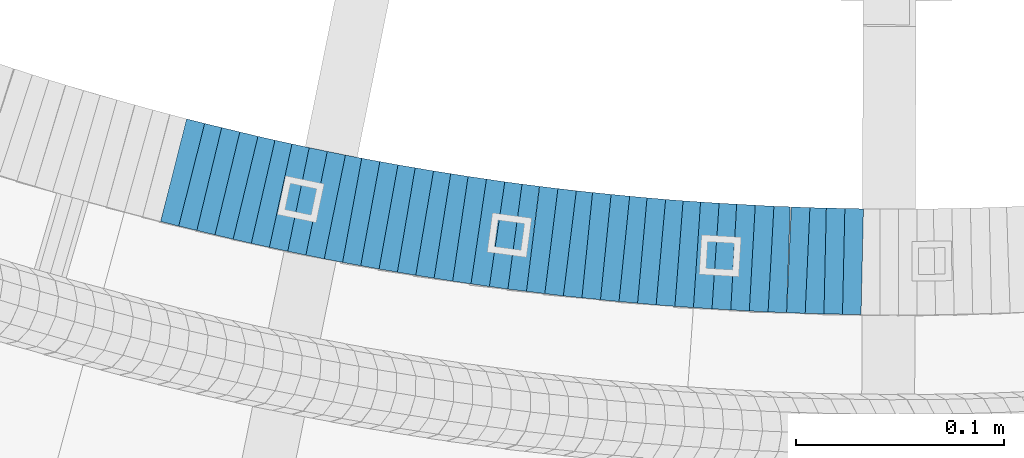
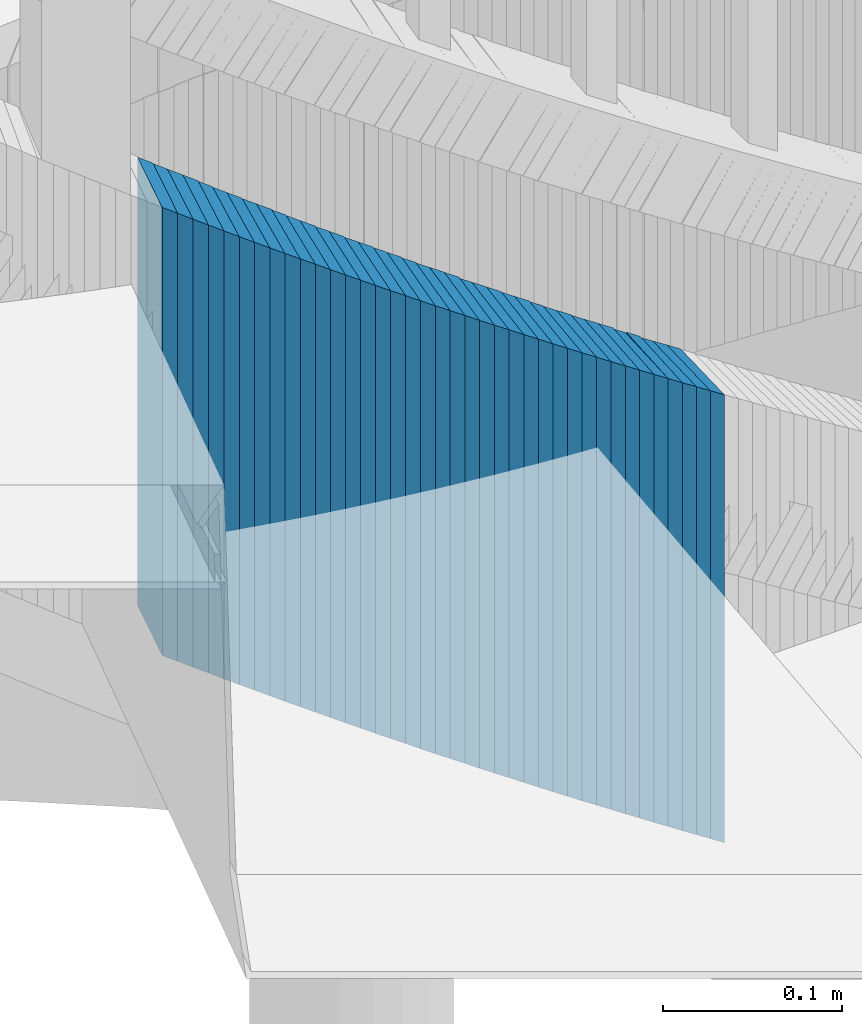
# One storey, part 880 of 975: 38 plates.
"""IFC2X3 building model written with IfcOpenShell, lengths in millimetres."""

from ifc_helpers import new_model, si_unit, frame, origin_with_axes, place, context, subcontext, project, spatial, faceted_brep, material, type_object, element, save


model = new_model("IFC2X3")

# Units and contexts
model_context = context("Model", 3, precision=1e-05, world=origin_with_axes())
body_context = subcontext(model_context, "Body", "Model", "MODEL_VIEW")
ifc_project = project(units=[si_unit("LENGTHUNIT", "METRE", prefix="MILLI"), si_unit("AREAUNIT", "SQUARE_METRE"), si_unit("VOLUMEUNIT", "CUBIC_METRE"), si_unit("MASSUNIT", "GRAM", prefix="KILO"), si_unit("TIMEUNIT", "SECOND"), si_unit("PLANEANGLEUNIT", "RADIAN"), si_unit("SOLIDANGLEUNIT", "STERADIAN"), si_unit("THERMODYNAMICTEMPERATUREUNIT", "DEGREE_CELSIUS"), si_unit("LUMINOUSINTENSITYUNIT", "LUMEN")], contexts=[model_context])

# Site, building, storey
site_placement = place(None, origin_with_axes())
site = spatial("IfcSite", under=ifc_project, at=site_placement, CompositionType="ELEMENT")
building_placement = place(site_placement, origin_with_axes())
building = spatial("IfcBuilding", under=site, at=building_placement, Name="Undefined", CompositionType="ELEMENT")
storey_placement = place(building_placement, origin_with_axes())
storey = spatial("IfcBuildingStorey", under=building, at=storey_placement, Name="Undefined", CompositionType="ELEMENT", Elevation=0.0)

# Plates
ifc_material = material(Name="STEEL/A36")
plate_type = type_object("IfcPlateType", PredefinedType="NOTDEFINED")
plate_1_placement = place(storey_placement, frame((34395.3922120382, 2048.29880946491, 3294.32500005032), z_axis=(-0.969483457737362, 0.245156735933585, 0.0), x_axis=(0.0, 0.0, 1.0)))
element("IfcPlate", 1, at=plate_1_placement, inside=storey, type_object=plate_type, material=ifc_material, Name="WALL", context=body_context, shape_type="Brep", body=[
    faceted_brep([(0.0, -25.3999999999724, -1.81898940354586e-11), (5.69999980926514, -25.4000000000124, 8.96939277650017), (5.69999980926514, 25.3999999999869, 8.96939277651836), (0.0, 25.3999999999869, 1.45519152283669e-11), (310.5, -25.4000000000124, 8.96939277650017), (310.5, 25.3999999999869, 8.96939277651836), (304.799987792969, -25.3999999999724, -1.81898940354586e-11), (304.799987792969, 25.3999999999869, 1.45519152283669e-11)], [[[0, 1, 2, 3]], [[1, 4, 5, 2]], [[4, 6, 7, 5]], [[6, 0, 3, 7]], [[5, 7, 3, 2]], [[6, 4, 1, 0]]]),
])
plate_2_placement = place(storey_placement, frame((34403.8251004839, 2046.26481773727, 3288.52500005032), z_axis=(-0.972082208620478, 0.234640532908391, 0.0), x_axis=(0.0, 0.0, 1.0)))
element("IfcPlate", 2, at=plate_2_placement, inside=storey, type_object=plate_type, material=ifc_material, Name="WALL", context=body_context, shape_type="Brep", body=[
    faceted_brep([(0.0, -25.3999999999724, -1.81898940354586e-11), (5.80000019073486, -25.3999999999942, 8.94930171964734), (5.80000019073486, 25.4000000000015, 8.94930171966917), (0.0, 25.3999999999869, 1.45519152283669e-11), (310.600006103516, -25.3999999999942, 8.94930171964734), (310.600006103516, 25.4000000000015, 8.94930171966917), (304.799987792969, -25.3999999999724, -1.81898940354586e-11), (304.799987792969, 25.3999999999869, 1.45519152283669e-11)], [[[0, 1, 2, 3]], [[1, 4, 5, 2]], [[4, 6, 7, 5]], [[6, 0, 3, 7]], [[5, 7, 3, 2]], [[6, 4, 1, 0]]]),
])
plate_3_placement = place(storey_placement, frame((34412.5251004863, 2044.16481773749, 3282.82500005032), z_axis=(-0.972082208620478, 0.234640532908391, 0.0), x_axis=(0.0, 0.0, 1.0)))
element("IfcPlate", 3, at=plate_3_placement, inside=storey, type_object=plate_type, material=ifc_material, Name="WALL", context=body_context, shape_type="Brep", body=[
    faceted_brep([(0.0, -25.3999999999724, -1.81898940354586e-11), (5.69999980926514, -25.3999999999869, 8.94930171964734), (5.69999980926514, 25.4000000000051, 8.94930171966917), (0.0, 25.3999999999869, 1.45519152283669e-11), (310.5, -25.3999999999869, 8.94930171964734), (310.5, 25.4000000000051, 8.94930171966917), (304.799987792969, -25.3999999999724, -1.81898940354586e-11), (304.799987792969, 25.3999999999869, 1.45519152283669e-11)], [[[0, 1, 2, 3]], [[1, 4, 5, 2]], [[4, 6, 7, 5]], [[6, 0, 3, 7]], [[5, 7, 3, 2]], [[6, 4, 1, 0]]]),
])
plate_4_placement = place(storey_placement, frame((34421.2251004888, 2042.06481773797, 3277.02500005032), z_axis=(-0.972082208620478, 0.234640532908391, 0.0), x_axis=(0.0, 0.0, 1.0)))
element("IfcPlate", 4, at=plate_4_placement, inside=storey, type_object=plate_type, material=ifc_material, Name="WALL", context=body_context, shape_type="Brep", body=[
    faceted_brep([(0.0, -25.3999999999724, -1.81898940354586e-11), (5.80000019073486, -25.3999999999942, 8.94930171964734), (5.80000019073486, 25.4000000000015, 8.94930171966917), (0.0, 25.3999999999869, 1.45519152283669e-11), (310.600006103516, -25.3999999999942, 8.94930171964734), (310.600006103516, 25.4000000000015, 8.94930171966917), (304.799987792969, -25.3999999999724, -1.81898940354586e-11), (304.799987792969, 25.3999999999869, 1.45519152283669e-11)], [[[0, 1, 2, 3]], [[1, 4, 5, 2]], [[4, 6, 7, 5]], [[6, 0, 3, 7]], [[5, 7, 3, 2]], [[6, 4, 1, 0]]]),
])
plate_5_placement = place(storey_placement, frame((34429.6558799515, 2040.12825277725, 3271.32500005032), z_axis=(-0.974579651097025, 0.224041299022304, 0.0), x_axis=(0.0, 0.0, 1.0)))
element("IfcPlate", 5, at=plate_5_placement, inside=storey, type_object=plate_type, material=ifc_material, Name="WALL", context=body_context, shape_type="Brep", body=[
    faceted_brep([(0.0, -25.3999999999724, -1.81898940354586e-11), (5.69999980926514, -25.3999999999542, 8.93084526058738), (5.69999980926514, 25.3999999999178, 8.93084526067832), (0.0, 25.3999999999869, 1.45519152283669e-11), (310.5, -25.3999999999542, 8.93084526058738), (310.5, 25.3999999999178, 8.93084526067832), (304.799987792969, -25.3999999999724, -1.81898940354586e-11), (304.799987792969, 25.3999999999869, 1.45519152283669e-11)], [[[0, 1, 2, 3]], [[1, 4, 5, 2]], [[4, 6, 7, 5]], [[6, 0, 3, 7]], [[5, 7, 3, 2]], [[6, 4, 1, 0]]]),
])
plate_6_placement = place(storey_placement, frame((34438.0846249187, 2038.28904940698, 3265.62500005032), z_axis=(-0.976973219192791, 0.213361967042104, 0.0), x_axis=(0.0, 0.0, 1.0)))
element("IfcPlate", 6, at=plate_6_placement, inside=storey, type_object=plate_type, material=ifc_material, Name="WALL", context=body_context, shape_type="Brep", body=[
    faceted_brep([(0.0, -25.3999999999724, -1.81898940354586e-11), (5.69999980926514, -25.4000000000269, 8.91066741947361), (5.69999980926514, 25.4000000000269, 8.91066741941904), (0.0, 25.3999999999869, 1.45519152283669e-11), (310.5, -25.4000000000269, 8.91066741947361), (310.5, 25.4000000000269, 8.91066741941904), (304.799987792969, -25.3999999999724, -1.81898940354586e-11), (304.799987792969, 25.3999999999869, 1.45519152283669e-11)], [[[0, 1, 2, 3]], [[1, 4, 5, 2]], [[4, 6, 7, 5]], [[6, 0, 3, 7]], [[5, 7, 3, 2]], [[6, 4, 1, 0]]]),
])
plate_7_placement = place(storey_placement, frame((34446.8257989563, 2036.40182344452, 3259.82500005032), z_axis=(-0.977476134047841, 0.211045984010329, 0.0), x_axis=(0.0, 0.0, 1.0)))
element("IfcPlate", 7, at=plate_7_placement, inside=storey, type_object=plate_type, material=ifc_material, Name="WALL", context=body_context, shape_type="Brep", body=[
    faceted_brep([(0.0, -25.3999999999724, -1.81898940354586e-11), (5.80000019073486, -25.3999999999978, 9.00055599211555), (5.80000019073486, 25.3999999999651, 9.00055599218103), (0.0, 25.3999999999869, 1.45519152283669e-11), (310.600006103516, -25.3999999999978, 9.00055599211555), (310.600006103516, 25.3999999999651, 9.00055599218103), (304.799987792969, -25.3999999999724, -1.81898940354586e-11), (304.799987792969, 25.3999999999869, 1.45519152283669e-11)], [[[0, 1, 2, 3]], [[1, 4, 5, 2]], [[4, 6, 7, 5]], [[6, 0, 3, 7]], [[5, 7, 3, 2]], [[6, 4, 1, 0]]]),
])
plate_8_placement = place(storey_placement, frame((34455.3114133024, 2034.64714429571, 3254.12500005032), z_axis=(-0.979260419534469, 0.202605603903684, 0.0), x_axis=(0.0, 0.0, 1.0)))
element("IfcPlate", 8, at=plate_8_placement, inside=storey, type_object=plate_type, material=ifc_material, Name="WALL", context=body_context, shape_type="Brep", body=[
    faceted_brep([(0.0, -25.3999999999724, -1.81898940354586e-11), (5.69999980926514, -25.4000000000306, 8.88144111634756), (5.69999980926514, 25.4000000000378, 8.88144111629663), (0.0, 25.3999999999869, 1.45519152283669e-11), (310.5, -25.4000000000306, 8.88144111634756), (310.5, 25.4000000000378, 8.88144111629663), (304.799987792969, -25.3999999999724, -1.81898940354586e-11), (304.799987792969, 25.3999999999869, 1.45519152283669e-11)], [[[0, 1, 2, 3]], [[1, 4, 5, 2]], [[4, 6, 7, 5]], [[6, 0, 3, 7]], [[5, 7, 3, 2]], [[6, 4, 1, 0]]]),
])
plate_9_placement = place(storey_placement, frame((34464.0552953596, 2032.8586889202, 3248.42500005032), z_axis=(-0.979714932300414, 0.200396236061448, 0.0), x_axis=(0.0, 0.0, 1.0)))
element("IfcPlate", 9, at=plate_9_placement, inside=storey, type_object=plate_type, material=ifc_material, Name="WALL", context=body_context, shape_type="Brep", body=[
    faceted_brep([(0.0, -25.3999999999724, -1.81898940354586e-11), (5.69999980926514, -25.3999999999542, 8.98276138300935), (5.69999980926514, 25.3999999999614, 8.98276138309302), (0.0, 25.3999999999869, 1.45519152283669e-11), (310.5, -25.3999999999542, 8.98276138300935), (310.5, 25.3999999999614, 8.98276138309302), (304.799987792969, -25.3999999999724, -1.81898940354586e-11), (304.799987792969, 25.3999999999869, 1.45519152283669e-11)], [[[0, 1, 2, 3]], [[1, 4, 5, 2]], [[4, 6, 7, 5]], [[6, 0, 3, 7]], [[5, 7, 3, 2]], [[6, 4, 1, 0]]]),
])
plate_10_placement = place(storey_placement, frame((34472.5829753509, 2031.21284178494, 3242.72500005032), z_axis=(-0.98184693485788, 0.189674975972544, 0.0), x_axis=(0.0, 0.0, 1.0)))
element("IfcPlate", 10, at=plate_10_placement, inside=storey, type_object=plate_type, material=ifc_material, Name="WALL", context=body_context, shape_type="Brep", body=[
    faceted_brep([(0.0, -25.3999999999724, -1.81898940354586e-11), (5.69999980926514, -25.3999999999105, 8.96270084374919), (5.69999980926514, 25.399999999936, 8.96270084385469), (0.0, 25.3999999999869, 1.45519152283669e-11), (310.5, -25.3999999999105, 8.96270084374919), (310.5, 25.399999999936, 8.96270084385469), (304.799987792969, -25.3999999999724, -1.81898940354586e-11), (304.799987792969, 25.3999999999869, 1.45519152283669e-11)], [[[0, 1, 2, 3]], [[1, 4, 5, 2]], [[4, 6, 7, 5]], [[6, 0, 3, 7]], [[5, 7, 3, 2]], [[6, 4, 1, 0]]]),
])
plate_11_placement = place(storey_placement, frame((34481.0594481925, 2029.65498582379, 3236.92500005032), z_axis=(-0.983506148975214, 0.180874693995442, 0.0), x_axis=(0.0, 0.0, 1.0)))
element("IfcPlate", 11, at=plate_11_placement, inside=storey, type_object=plate_type, material=ifc_material, Name="WALL", context=body_context, shape_type="Brep", body=[
    faceted_brep([(0.0, -25.3999999999724, -1.81898940354586e-11), (5.80000019073486, -25.4000000000378, 8.84590339667557), (5.80000019073486, 25.4000000000415, 8.8459033965446), (0.0, 25.3999999999869, 1.45519152283669e-11), (310.600006103516, -25.4000000000378, 8.84590339667557), (310.600006103516, 25.4000000000415, 8.8459033965446), (304.799987792969, -25.3999999999724, -1.81898940354586e-11), (304.799987792969, 25.3999999999869, 1.45519152283669e-11)], [[[0, 1, 2, 3]], [[1, 4, 5, 2]], [[4, 6, 7, 5]], [[6, 0, 3, 7]], [[5, 7, 3, 2]], [[6, 4, 1, 0]]]),
])
plate_12_placement = place(storey_placement, frame((34489.8089210954, 2028.064225357, 3231.22500005032), z_axis=(-0.983869910131907, 0.178885438023983, 0.0), x_axis=(0.0, 0.0, 1.0)))
element("IfcPlate", 12, at=plate_12_placement, inside=storey, type_object=plate_type, material=ifc_material, Name="WALL", context=body_context, shape_type="Brep", body=[
    faceted_brep([(0.0, -25.3999999999724, -1.81898940354586e-11), (5.69999980926514, -25.4000000000851, 8.94035816198448), (5.69999980926514, 25.4000000000524, 8.94035816188989), (0.0, 25.3999999999869, 1.45519152283669e-11), (310.5, -25.4000000000851, 8.94035816198448), (310.5, 25.4000000000524, 8.94035816188989), (304.799987792969, -25.3999999999724, -1.81898940354586e-11), (304.799987792969, 25.3999999999869, 1.45519152283669e-11)], [[[0, 1, 2, 3]], [[1, 4, 5, 2]], [[4, 6, 7, 5]], [[6, 0, 3, 7]], [[5, 7, 3, 2]], [[6, 4, 1, 0]]]),
])
plate_13_placement = place(storey_placement, frame((34498.3332177071, 2026.61278522843, 3225.52500005032), z_axis=(-0.985781716087097, 0.168030974014846, 0.0), x_axis=(0.0, 0.0, 1.0)))
element("IfcPlate", 13, at=plate_13_placement, inside=storey, type_object=plate_type, material=ifc_material, Name="WALL", context=body_context, shape_type="Brep", body=[
    faceted_brep([(0.0, -25.3999999999724, -1.81898940354586e-11), (5.69999980926514, -25.3999999999542, 8.93084526058738), (5.69999980926514, 25.3999999999178, 8.93084526067832), (0.0, 25.3999999999869, 1.45519152283669e-11), (310.5, -25.3999999999542, 8.93084526058738), (310.5, 25.3999999999178, 8.93084526067832), (304.799987792969, -25.3999999999724, -1.81898940354586e-11), (304.799987792969, 25.3999999999869, 1.45519152283669e-11)], [[[0, 1, 2, 3]], [[1, 4, 5, 2]], [[4, 6, 7, 5]], [[6, 0, 3, 7]], [[5, 7, 3, 2]], [[6, 4, 1, 0]]]),
])
plate_14_placement = place(storey_placement, frame((34507.1332177047, 2025.11278522859, 3219.72500005032), z_axis=(-0.985781716087097, 0.168030974014846, 0.0), x_axis=(0.0, 0.0, 1.0)))
element("IfcPlate", 14, at=plate_14_placement, inside=storey, type_object=plate_type, material=ifc_material, Name="WALL", context=body_context, shape_type="Brep", body=[
    faceted_brep([(0.0, -25.3999999999724, -1.81898940354586e-11), (5.80000019073486, -25.3999999999869, 8.93084526053281), (5.80000019073486, 25.3999999999833, 8.9308452607147), (0.0, 25.3999999999869, 1.45519152283669e-11), (310.600006103516, -25.3999999999869, 8.93084526053281), (310.600006103516, 25.3999999999833, 8.9308452607147), (304.799987792969, -25.3999999999724, -1.81898940354586e-11), (304.799987792969, 25.3999999999869, 1.45519152283669e-11)], [[[0, 1, 2, 3]], [[1, 4, 5, 2]], [[4, 6, 7, 5]], [[6, 0, 3, 7]], [[5, 7, 3, 2]], [[6, 4, 1, 0]]]),
])
plate_15_placement = place(storey_placement, frame((34515.6559532135, 2023.75846941976, 3214.02500005032), z_axis=(-0.987580306285744, 0.157115049045459, 0.0), x_axis=(0.0, 0.0, 1.0)))
element("IfcPlate", 15, at=plate_15_placement, inside=storey, type_object=plate_type, material=ifc_material, Name="WALL", context=body_context, shape_type="Brep", body=[
    faceted_brep([(0.0, -25.3999999999724, -1.81898940354586e-11), (5.69999980926514, -25.4000000000269, 8.91066741947361), (5.69999980926514, 25.4000000000269, 8.91066741941904), (0.0, 25.3999999999869, 1.45519152283669e-11), (310.5, -25.4000000000269, 8.91066741947361), (310.5, 25.4000000000269, 8.91066741941904), (304.799987792969, -25.3999999999724, -1.81898940354586e-11), (304.799987792969, 25.3999999999869, 1.45519152283669e-11)], [[[0, 1, 2, 3]], [[1, 4, 5, 2]], [[4, 6, 7, 5]], [[6, 0, 3, 7]], [[5, 7, 3, 2]], [[6, 4, 1, 0]]]),
])
plate_16_placement = place(storey_placement, frame((34524.5122023689, 2022.36539067251, 3208.32500005032), z_axis=(-0.987852796552575, 0.155392574929619, 0.0), x_axis=(0.0, 0.0, 1.0)))
element("IfcPlate", 16, at=plate_16_placement, inside=storey, type_object=plate_type, material=ifc_material, Name="WALL", context=body_context, shape_type="Brep", body=[
    faceted_brep([(0.0, -25.3999999999724, -1.81898940354586e-11), (5.69999980926514, -25.4000000000233, 9.01387786867781), (5.69999980926514, 25.400000000016, 9.01387786863415), (0.0, 25.3999999999869, 1.45519152283669e-11), (310.5, -25.4000000000233, 9.01387786867781), (310.5, 25.400000000016, 9.01387786863415), (304.799987792969, -25.3999999999724, -1.81898940354586e-11), (304.799987792969, 25.3999999999869, 1.45519152283669e-11)], [[[0, 1, 2, 3]], [[1, 4, 5, 2]], [[4, 6, 7, 5]], [[6, 0, 3, 7]], [[5, 7, 3, 2]], [[6, 4, 1, 0]]]),
])
plate_17_placement = place(storey_placement, frame((34533.077218307, 2021.10122853883, 3202.52500005032), z_axis=(-0.989263736178206, 0.146141234026326, 0.0), x_axis=(0.0, 0.0, 1.0)))
element("IfcPlate", 17, at=plate_17_placement, inside=storey, type_object=plate_type, material=ifc_material, Name="WALL", context=body_context, shape_type="Brep", body=[
    faceted_brep([(0.0, -25.3999999999724, -1.81898940354586e-11), (5.80000019073486, -25.3999999999687, 8.90449333185097), (5.80000019073486, 25.3999999999833, 8.90449333192373), (0.0, 25.3999999999869, 1.45519152283669e-11), (310.600006103516, -25.3999999999687, 8.90449333185097), (310.600006103516, 25.3999999999833, 8.90449333192373), (304.799987792969, -25.3999999999724, -1.81898940354586e-11), (304.799987792969, 25.3999999999869, 1.45519152283669e-11)], [[[0, 1, 2, 3]], [[1, 4, 5, 2]], [[4, 6, 7, 5]], [[6, 0, 3, 7]], [[5, 7, 3, 2]], [[6, 4, 1, 0]]]),
])
plate_18_placement = place(storey_placement, frame((34541.877218304, 2019.80122853885, 3196.82500005032), z_axis=(-0.989263736178206, 0.146141234026326, 0.0), x_axis=(0.0, 0.0, 1.0)))
element("IfcPlate", 18, at=plate_18_placement, inside=storey, type_object=plate_type, material=ifc_material, Name="WALL", context=body_context, shape_type="Brep", body=[
    faceted_brep([(0.0, -25.3999999999724, -1.81898940354586e-11), (5.69999980926514, -25.3999999999469, 8.90224647518698), (5.69999980926514, 25.399999999936, 8.90224647526338), (0.0, 25.3999999999869, 1.45519152283669e-11), (310.5, -25.3999999999469, 8.90224647518698), (310.5, 25.399999999936, 8.90224647526338), (304.799987792969, -25.3999999999724, -1.81898940354586e-11), (304.799987792969, 25.3999999999869, 1.45519152283669e-11)], [[[0, 1, 2, 3]], [[1, 4, 5, 2]], [[4, 6, 7, 5]], [[6, 0, 3, 7]], [[5, 7, 3, 2]], [[6, 4, 1, 0]]]),
])
plate_19_placement = place(storey_placement, frame((34550.4592382899, 2018.64615072209, 3191.12500005033), z_axis=(-0.991032326071817, 0.133622336009683, 0.0), x_axis=(0.0, 0.0, 1.0)))
element("IfcPlate", 19, at=plate_19_placement, inside=storey, type_object=plate_type, material=ifc_material, Name="WALL", context=body_context, shape_type="Brep", body=[
    faceted_brep([(0.0, -25.3999999999724, -1.81898940354586e-11), (5.69999980926514, -25.3999999999542, 8.98276138300935), (5.69999980926514, 25.3999999999614, 8.98276138309302), (0.0, 25.3999999999869, 1.45519152283669e-11), (310.5, -25.3999999999542, 8.98276138300935), (310.5, 25.3999999999614, 8.98276138309302), (304.799987792969, -25.3999999999724, -1.81898940354586e-11), (304.799987792969, 25.3999999999869, 1.45519152283669e-11)], [[[0, 1, 2, 3]], [[1, 4, 5, 2]], [[4, 6, 7, 5]], [[6, 0, 3, 7]], [[5, 7, 3, 2]], [[6, 4, 1, 0]]]),
])
plate_20_placement = place(storey_placement, frame((34559.0808501246, 2017.5821211099, 3185.42500005033), z_axis=(-0.99244848307505, 0.122662172009276, 0.0), x_axis=(0.0, 0.0, 1.0)))
element("IfcPlate", 20, at=plate_20_placement, inside=storey, type_object=plate_type, material=ifc_material, Name="WALL", context=body_context, shape_type="Brep", body=[
    faceted_brep([(0.0, -25.3999999999724, -1.81898940354586e-11), (5.69999980926514, -25.4000000000124, 8.96939277650017), (5.69999980926514, 25.3999999999869, 8.96939277651836), (0.0, 25.3999999999869, 1.45519152283669e-11), (310.5, -25.4000000000124, 8.96939277650017), (310.5, 25.3999999999869, 8.96939277651836), (304.799987792969, -25.3999999999724, -1.81898940354586e-11), (304.799987792969, 25.3999999999869, 1.45519152283669e-11)], [[[0, 1, 2, 3]], [[1, 4, 5, 2]], [[4, 6, 7, 5]], [[6, 0, 3, 7]], [[5, 7, 3, 2]], [[6, 4, 1, 0]]]),
])
plate_21_placement = place(storey_placement, frame((34567.9157132253, 2016.47778770714, 3179.62500005033), z_axis=(-0.992277876667514, 0.12403473495844, 0.0), x_axis=(0.0, 0.0, 1.0)))
element("IfcPlate", 21, at=plate_21_placement, inside=storey, type_object=plate_type, material=ifc_material, Name="WALL", context=body_context, shape_type="Brep", body=[
    faceted_brep([(0.0, -25.3999999999724, -1.81898940354586e-11), (5.80000019073486, -25.4000000000042, 8.87299251562217), (5.80000019073486, 25.3999999999987, 8.87299251556396), (0.0, 25.3999999999869, 1.45519152283669e-11), (310.600006103516, -25.4000000000042, 8.87299251562217), (310.600006103516, 25.3999999999987, 8.87299251556396), (304.799987792969, -25.3999999999724, -1.81898940354586e-11), (304.799987792969, 25.3999999999869, 1.45519152283669e-11)], [[[0, 1, 2, 3]], [[1, 4, 5, 2]], [[4, 6, 7, 5]], [[6, 0, 3, 7]], [[5, 7, 3, 2]], [[6, 4, 1, 0]]]),
])
plate_22_placement = place(storey_placement, frame((34576.7808501268, 2015.38212111014, 3173.92500005033), z_axis=(-0.99244848307505, 0.122662172009276, 0.0), x_axis=(0.0, 0.0, 1.0)))
element("IfcPlate", 22, at=plate_22_placement, inside=storey, type_object=plate_type, material=ifc_material, Name="WALL", context=body_context, shape_type="Brep", body=[
    faceted_brep([(0.0, -25.3999999999724, -1.81898940354586e-11), (5.69999980926514, -25.4000000000124, 8.96939277650017), (5.69999980926514, 25.3999999999869, 8.96939277651836), (0.0, 25.3999999999869, 1.45519152283669e-11), (310.5, -25.4000000000124, 8.96939277650017), (310.5, 25.3999999999869, 8.96939277651836), (304.799987792969, -25.3999999999724, -1.81898940354586e-11), (304.799987792969, 25.3999999999869, 1.45519152283669e-11)], [[[0, 1, 2, 3]], [[1, 4, 5, 2]], [[4, 6, 7, 5]], [[6, 0, 3, 7]], [[5, 7, 3, 2]], [[6, 4, 1, 0]]]),
])
plate_23_placement = place(storey_placement, frame((34585.1207372207, 2014.5450472985, 3168.22500005033), z_axis=(-0.994925892068904, 0.100610483006968, 0.0), x_axis=(0.0, 0.0, 1.0)))
element("IfcPlate", 23, at=plate_23_placement, inside=storey, type_object=plate_type, material=ifc_material, Name="WALL", context=body_context, shape_type="Brep", body=[
    faceted_brep([(0.0, -25.3999999999724, -1.81898940354586e-11), (5.69999980926514, -25.3999999999869, 8.94930171964734), (5.69999980926514, 25.4000000000051, 8.94930171966917), (0.0, 25.3999999999869, 1.45519152283669e-11), (310.5, -25.3999999999869, 8.94930171964734), (310.5, 25.4000000000051, 8.94930171966917), (304.799987792969, -25.3999999999724, -1.81898940354586e-11), (304.799987792969, 25.3999999999869, 1.45519152283669e-11)], [[[0, 1, 2, 3]], [[1, 4, 5, 2]], [[4, 6, 7, 5]], [[6, 0, 3, 7]], [[5, 7, 3, 2]], [[6, 4, 1, 0]]]),
])
plate_24_placement = place(storey_placement, frame((34594.0207372153, 2013.64504729841, 3162.42500005033), z_axis=(-0.994925892068904, 0.100610483006968, 0.0), x_axis=(0.0, 0.0, 1.0)))
element("IfcPlate", 24, at=plate_24_placement, inside=storey, type_object=plate_type, material=ifc_material, Name="WALL", context=body_context, shape_type="Brep", body=[
    faceted_brep([(0.0, -25.3999999999724, -1.81898940354586e-11), (5.80000019073486, -25.3999999999942, 8.94930171964734), (5.80000019073486, 25.4000000000015, 8.94930171966917), (0.0, 25.3999999999869, 1.45519152283669e-11), (310.600006103516, -25.3999999999942, 8.94930171964734), (310.600006103516, 25.4000000000015, 8.94930171966917), (304.799987792969, -25.3999999999724, -1.81898940354586e-11), (304.799987792969, 25.3999999999869, 1.45519152283669e-11)], [[[0, 1, 2, 3]], [[1, 4, 5, 2]], [[4, 6, 7, 5]], [[6, 0, 3, 7]], [[5, 7, 3, 2]], [[6, 4, 1, 0]]]),
])
plate_25_placement = place(storey_placement, frame((34602.9207372098, 2012.74504729836, 3156.72500005033), z_axis=(-0.994925892068904, 0.100610483006968, 0.0), x_axis=(0.0, 0.0, 1.0)))
element("IfcPlate", 25, at=plate_25_placement, inside=storey, type_object=plate_type, material=ifc_material, Name="WALL", context=body_context, shape_type="Brep", body=[
    faceted_brep([(0.0, -25.3999999999724, -1.81898940354586e-11), (5.69999980926514, -25.3999999999869, 8.94930171964734), (5.69999980926514, 25.4000000000051, 8.94930171966917), (0.0, 25.3999999999869, 1.45519152283669e-11), (310.5, -25.3999999999869, 8.94930171964734), (310.5, 25.4000000000051, 8.94930171966917), (304.799987792969, -25.3999999999724, -1.81898940354586e-11), (304.799987792969, 25.3999999999869, 1.45519152283669e-11)], [[[0, 1, 2, 3]], [[1, 4, 5, 2]], [[4, 6, 7, 5]], [[6, 0, 3, 7]], [[5, 7, 3, 2]], [[6, 4, 1, 0]]]),
])
plate_26_placement = place(storey_placement, frame((34611.5392088716, 2011.97193399573, 3150.92500005033), z_axis=(-0.995984423457655, 0.0895266900411377, 0.0), x_axis=(0.0, 0.0, 1.0)))
element("IfcPlate", 26, at=plate_26_placement, inside=storey, type_object=plate_type, material=ifc_material, Name="WALL", context=body_context, shape_type="Brep", body=[
    faceted_brep([(0.0, -25.3999999999724, -1.81898940354586e-11), (5.80000019073486, -25.4000000000087, 8.9375610351708), (5.80000019073486, 25.400000000016, 8.93756103512715), (0.0, 25.3999999999869, 1.45519152283669e-11), (310.600006103516, -25.4000000000087, 8.9375610351708), (310.600006103516, 25.400000000016, 8.93756103512715), (304.799987792969, -25.3999999999724, -1.81898940354586e-11), (304.799987792969, 25.3999999999869, 1.45519152283669e-11)], [[[0, 1, 2, 3]], [[1, 4, 5, 2]], [[4, 6, 7, 5]], [[6, 0, 3, 7]], [[5, 7, 3, 2]], [[6, 4, 1, 0]]]),
])
plate_27_placement = place(storey_placement, frame((34620.4392088747, 2011.17193399579, 3145.22500005033), z_axis=(-0.995984423457655, 0.0895266900411377, 0.0), x_axis=(0.0, 0.0, 1.0)))
element("IfcPlate", 27, at=plate_27_placement, inside=storey, type_object=plate_type, material=ifc_material, Name="WALL", context=body_context, shape_type="Brep", body=[
    faceted_brep([(0.0, -25.3999999999724, -1.81898940354586e-11), (5.69999980926514, -25.4000000000851, 8.94035816198448), (5.69999980926514, 25.4000000000524, 8.94035816188989), (0.0, 25.3999999999869, 1.45519152283669e-11), (310.5, -25.4000000000851, 8.94035816198448), (310.5, 25.4000000000524, 8.94035816188989), (304.799987792969, -25.3999999999724, -1.81898940354586e-11), (304.799987792969, 25.3999999999869, 1.45519152283669e-11)], [[[0, 1, 2, 3]], [[1, 4, 5, 2]], [[4, 6, 7, 5]], [[6, 0, 3, 7]], [[5, 7, 3, 2]], [[6, 4, 1, 0]]]),
])
plate_28_placement = place(storey_placement, frame((34629.134838025, 2010.49744929907, 3139.42500005033), z_axis=(-0.996988962963333, 0.0775435859971479, 0.0), x_axis=(0.0, 0.0, 1.0)))
element("IfcPlate", 28, at=plate_28_placement, inside=storey, type_object=plate_type, material=ifc_material, Name="WALL", context=body_context, shape_type="Brep", body=[
    faceted_brep([(0.0, -25.3999999999724, -1.81898940354586e-11), (5.80000019073486, -25.4000000000015, 9.02718162538804), (5.80000019073486, 25.4000000000005, 9.02718162535166), (0.0, 25.3999999999869, 1.45519152283669e-11), (310.600006103516, -25.4000000000015, 9.02718162538804), (310.600006103516, 25.4000000000005, 9.02718162535166), (304.799987792969, -25.3999999999724, -1.81898940354586e-11), (304.799987792969, 25.3999999999869, 1.45519152283669e-11)], [[[0, 1, 2, 3]], [[1, 4, 5, 2]], [[4, 6, 7, 5]], [[6, 0, 3, 7]], [[5, 7, 3, 2]], [[6, 4, 1, 0]]]),
])
for number, where, z_axis, x_axis, name in (
    (29, (34637.7737124614, 2009.91640566123, 3133.72500005033), (-0.99773527642945, 0.0672630520289514, 0.0), (0.0, 0.0, 1.0), "WALL"),
    (30, (34646.6737124605, 2009.31640566107, 3128.02500005033), (-0.99773527642945, 0.0672630520289514, 0.0), (0.0, 0.0, 1.0), "WALL"),
):
    element("IfcPlate", number, at=place(storey_placement, frame(where, z_axis=z_axis, x_axis=x_axis)), inside=storey, type_object=plate_type, material=ifc_material, Name=name, context=body_context, shape_type="Brep", body=[
        faceted_brep([(0.0, -25.3999999999724, -1.81898940354586e-11), (5.69999980926514, -25.4000000000269, 8.9196414947728), (5.69999980926514, 25.3999999999796, 8.91964149476189), (0.0, 25.3999999999869, 1.45519152283669e-11), (310.5, -25.4000000000269, 8.9196414947728), (310.5, 25.3999999999796, 8.91964149476189), (304.799987792969, -25.3999999999724, -1.81898940354586e-11), (304.799987792969, 25.3999999999869, 1.45519152283669e-11)], [[[0, 1, 2, 3]], [[1, 4, 5, 2]], [[4, 6, 7, 5]], [[6, 0, 3, 7]], [[5, 7, 3, 2]], [[6, 4, 1, 0]]]),
    ])
plate_29_placement = place(storey_placement, frame((34655.3741694461, 2008.83482261074, 3122.22500005033), z_axis=(-0.998460353183874, 0.0554700200102153, 0.0), x_axis=(0.0, 0.0, 1.0)))
element("IfcPlate", 31, at=plate_29_placement, inside=storey, type_object=plate_type, material=ifc_material, Name="WALL", context=body_context, shape_type="Brep", body=[
    faceted_brep([(0.0, -25.3999999999724, -1.81898940354586e-11), (5.80000019073486, -25.400000000016, 9.01387786866326), (5.80000019073486, 25.4000000000306, 9.01387786864143), (0.0, 25.3999999999869, 1.45519152283669e-11), (310.600006103515, -25.400000000016, 9.01387786866326), (310.600006103515, 25.4000000000306, 9.01387786864143), (304.799987792969, -25.3999999999724, -1.81898940354586e-11), (304.799987792969, 25.3999999999869, 1.45519152283669e-11)], [[[0, 1, 2, 3]], [[1, 4, 5, 2]], [[4, 6, 7, 5]], [[6, 0, 3, 7]], [[5, 7, 3, 2]], [[6, 4, 1, 0]]]),
])
plate_30_placement = place(storey_placement, frame((34664.2899506657, 2008.33394095085, 3116.52500005033), z_axis=(-0.99842564215979, 0.056091328008977, 0.0), x_axis=(0.0, 0.0, 1.0)))
element("IfcPlate", 32, at=plate_30_placement, inside=storey, type_object=plate_type, material=ifc_material, Name="WALL", context=body_context, shape_type="Brep", body=[
    faceted_brep([(0.0, -25.3999999999724, -1.81898940354586e-11), (5.69999980926514, -25.4000000000269, 8.91066741947361), (5.69999980926514, 25.4000000000269, 8.91066741941904), (0.0, 25.3999999999869, 1.45519152283669e-11), (310.5, -25.4000000000269, 8.91066741947361), (310.5, 25.4000000000269, 8.91066741941904), (304.799987792969, -25.3999999999724, -1.81898940354586e-11), (304.799987792969, 25.3999999999869, 1.45519152283669e-11)], [[[0, 1, 2, 3]], [[1, 4, 5, 2]], [[4, 6, 7, 5]], [[6, 0, 3, 7]], [[5, 7, 3, 2]], [[6, 4, 1, 0]]]),
])
plate_31_placement = place(storey_placement, frame((34673.2741694414, 2007.83482261095, 3110.72500005033), z_axis=(-0.998460353183874, 0.0554700200102153, 0.0), x_axis=(0.0, 0.0, 1.0)))
element("IfcPlate", 33, at=plate_31_placement, inside=storey, type_object=plate_type, material=ifc_material, Name="WALL", context=body_context, shape_type="Brep", body=[
    faceted_brep([(0.0, -25.3999999999724, -1.81898940354586e-11), (5.80000019073486, -25.400000000016, 9.01387786866326), (5.80000019073486, 25.4000000000306, 9.01387786864143), (0.0, 25.3999999999869, 1.45519152283669e-11), (310.600006103515, -25.400000000016, 9.01387786866326), (310.600006103515, 25.4000000000306, 9.01387786864143), (304.799987792969, -25.3999999999724, -1.81898940354586e-11), (304.799987792969, 25.3999999999869, 1.45519152283669e-11)], [[[0, 1, 2, 3]], [[1, 4, 5, 2]], [[4, 6, 7, 5]], [[6, 0, 3, 7]], [[5, 7, 3, 2]], [[6, 4, 1, 0]]]),
])
plate_32_placement = place(storey_placement, frame((34681.6209247209, 2007.55951192888, 3105.02500005033), z_axis=(-0.999432373568723, 0.0336887319854628, 0.0), x_axis=(0.0, 0.0, 1.0)))
element("IfcPlate", 34, at=plate_32_placement, inside=storey, type_object=plate_type, material=ifc_material, Name="WALL", context=body_context, shape_type="Brep", body=[
    faceted_brep([(0.0, -25.3999999999724, -1.81898940354586e-11), (5.69999980926514, -25.4000000000269, 8.91066741947361), (5.69999980926514, 25.4000000000269, 8.91066741941904), (0.0, 25.3999999999869, 1.45519152283669e-11), (310.5, -25.4000000000269, 8.91066741947361), (310.5, 25.4000000000269, 8.91066741941904), (304.799987792969, -25.3999999999724, -1.81898940354586e-11), (304.799987792969, 25.3999999999869, 1.45519152283669e-11)], [[[0, 1, 2, 3]], [[1, 4, 5, 2]], [[4, 6, 7, 5]], [[6, 0, 3, 7]], [[5, 7, 3, 2]], [[6, 4, 1, 0]]]),
])
plate_33_placement = place(storey_placement, frame((34690.8056527481, 2007.14831511167, 3099.22500005033), z_axis=(-0.998991554001901, 0.0448984970000857, 0.0), x_axis=(0.0, 0.0, 1.0)))
element("IfcPlate", 35, at=plate_33_placement, inside=storey, type_object=plate_type, material=ifc_material, Name="WALL", context=body_context, shape_type="Brep", body=[
    faceted_brep([(0.0, -25.3999999999724, -1.81898940354586e-11), (5.80000019073486, -25.3999999999796, 8.91403388975959), (5.80000019073486, 25.3999999999432, 8.91403388980689), (0.0, 25.3999999999869, 1.45519152283669e-11), (310.600006103515, -25.3999999999796, 8.91403388975959), (310.600006103515, 25.3999999999432, 8.91403388980689), (304.799987792969, -25.3999999999724, -1.81898940354586e-11), (304.799987792969, 25.3999999999869, 1.45519152283669e-11)], [[[0, 1, 2, 3]], [[1, 4, 5, 2]], [[4, 6, 7, 5]], [[6, 0, 3, 7]], [[5, 7, 3, 2]], [[6, 4, 1, 0]]]),
])
plate_34_placement = place(storey_placement, frame((34699.2295360493, 2006.96766035706, 3093.52500005033), z_axis=(-0.999753177838027, 0.0222167369964006, 0.0), x_axis=(0.0, 0.0, 1.0)))
element("IfcPlate", 36, at=plate_34_placement, inside=storey, type_object=plate_type, material=ifc_material, Name="WALL", context=body_context, shape_type="Brep", body=[
    faceted_brep([(0.0, -25.3999999999724, -1.81898940354586e-11), (5.69999980926514, -25.3999999999978, 9.00277709959482), (5.69999980926514, 25.3999999999651, 9.00277709966031), (0.0, 25.3999999999869, 1.45519152283669e-11), (310.5, -25.3999999999978, 9.00277709959482), (310.5, 25.3999999999651, 9.00277709966031), (304.799987792969, -25.3999999999724, -1.81898940354586e-11), (304.799987792969, 25.3999999999869, 1.45519152283669e-11)], [[[0, 1, 2, 3]], [[1, 4, 5, 2]], [[4, 6, 7, 5]], [[6, 0, 3, 7]], [[5, 7, 3, 2]], [[6, 4, 1, 0]]]),
])
plate_35_placement = place(storey_placement, frame((34708.1358733724, 2006.76751873634, 3087.82500005033), z_axis=(-0.999747602222632, 0.0224662380050029, 0.0), x_axis=(0.0, 0.0, 1.0)))
element("IfcPlate", 37, at=plate_35_placement, inside=storey, type_object=plate_type, material=ifc_material, Name="WALL", context=body_context, shape_type="Brep", body=[
    faceted_brep([(0.0, -25.3999999999724, -1.81898940354586e-11), (5.69999980926514, -25.3999999999469, 8.90224647518698), (5.69999980926514, 25.399999999936, 8.90224647526338), (0.0, 25.3999999999869, 1.45519152283669e-11), (310.5, -25.3999999999469, 8.90224647518698), (310.5, 25.399999999936, 8.90224647526338), (304.799987792969, -25.3999999999724, -1.81898940354586e-11), (304.799987792969, 25.3999999999869, 1.45519152283669e-11)], [[[0, 1, 2, 3]], [[1, 4, 5, 2]], [[4, 6, 7, 5]], [[6, 0, 3, 7]], [[5, 7, 3, 2]], [[6, 4, 1, 0]]]),
])
plate_36_placement = place(storey_placement, frame((34717.0358733697, 2006.56751873637, 3082.02500005033), z_axis=(-0.999747602222632, 0.0224662380050029, 0.0), x_axis=(0.0, 0.0, 1.0)))
element("IfcPlate", 38, at=plate_36_placement, inside=storey, type_object=plate_type, material=ifc_material, Name="WALL", context=body_context, shape_type="Brep", body=[
    faceted_brep([(0.0, -25.3999999999724, -1.81898940354586e-11), (5.80000019073486, -25.3999999999687, 8.90449333185097), (5.80000019073486, 25.3999999999833, 8.90449333192373), (0.0, 25.3999999999869, 1.45519152283669e-11), (310.600006103516, -25.3999999999687, 8.90449333185097), (310.600006103516, 25.3999999999833, 8.90449333192373), (304.799987792969, -25.3999999999724, -1.81898940354586e-11), (304.799987792969, 25.3999999999869, 1.45519152283669e-11)], [[[0, 1, 2, 3]], [[1, 4, 5, 2]], [[4, 6, 7, 5]], [[6, 0, 3, 7]], [[5, 7, 3, 2]], [[6, 4, 1, 0]]]),
])

save(model, "model.ifc")
